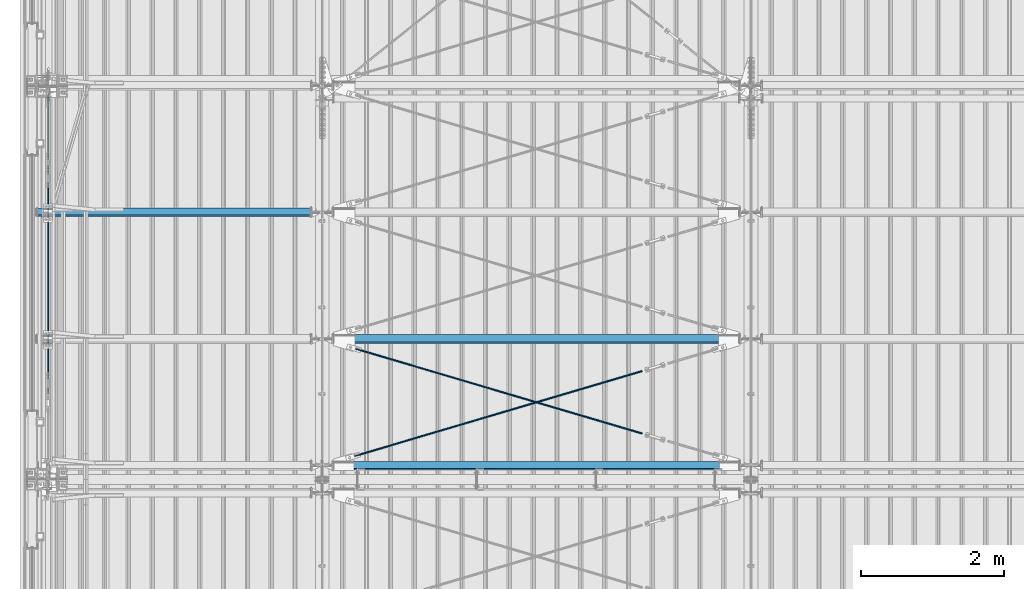
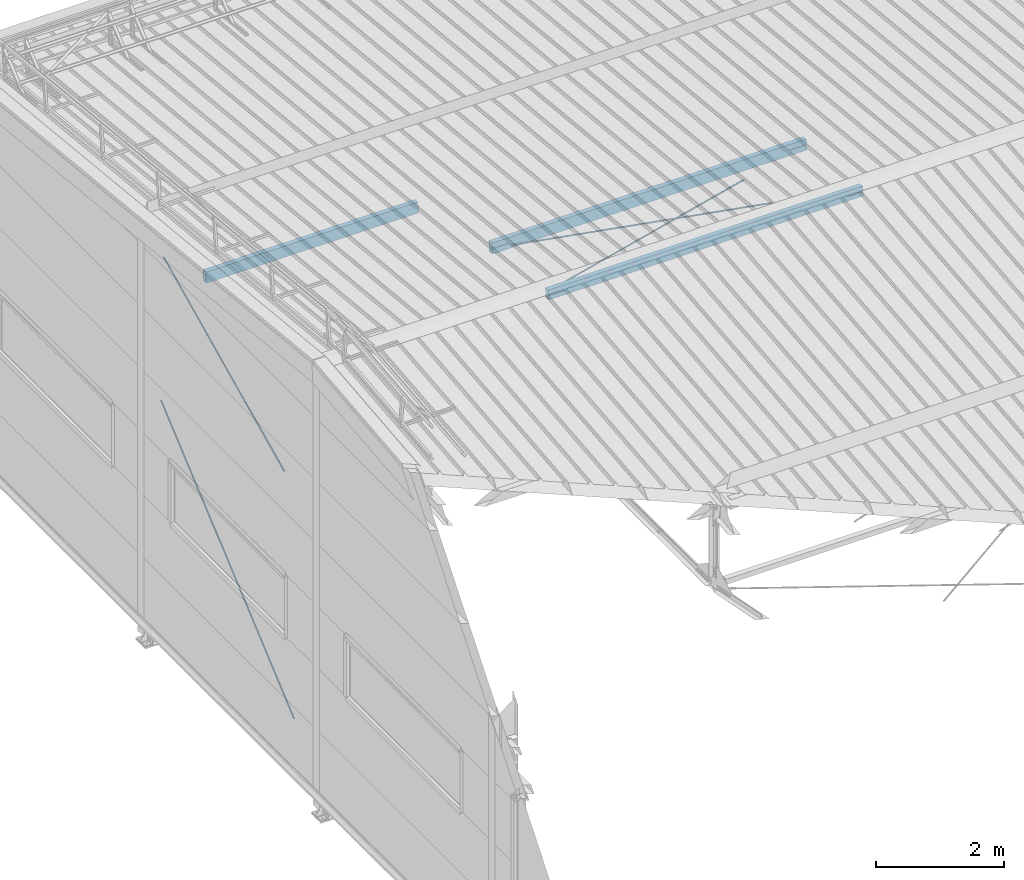
# One storey, part 248 of 709: 5 beams, 2 members, 8 openings, 7 elements without a shape of their own.
"""IFC4 building model written with IfcOpenShell, lengths in millimetres."""

from ifc_helpers import new_model, si_unit, direction, frame, origin_with_axes, place, context, subcontext, project, spatial, line, indexed_curve, outline, extrude, polygons, material, element, aggregate, save


model = new_model("IFC4")

# Units and contexts
model_context = context("Model", 3, precision=0.2, world=origin_with_axes(), true_north=direction((0.0, 1.0)))
body_context = subcontext(model_context, "Body", "Model", "MODEL_VIEW")
reference_context = subcontext(model_context, "Reference", "Model", "MODEL_VIEW")
ifc_project = project(units=[si_unit("LENGTHUNIT", "METRE", prefix="MILLI"), si_unit("AREAUNIT", "SQUARE_METRE"), si_unit("VOLUMEUNIT", "CUBIC_METRE"), si_unit("MASSUNIT", "GRAM", prefix="KILO"), si_unit("TIMEUNIT", "SECOND"), si_unit("PLANEANGLEUNIT", "RADIAN"), si_unit("SOLIDANGLEUNIT", "STERADIAN"), si_unit("THERMODYNAMICTEMPERATUREUNIT", "DEGREE_CELSIUS"), si_unit("LUMINOUSINTENSITYUNIT", "LUMEN")], contexts=[model_context])

# Site, building, storey
site_placement = place(None, origin_with_axes())
site = spatial("IfcSite", under=ifc_project, at=site_placement, CompositionType="ELEMENT")
building_placement = place(site_placement, origin_with_axes())
building = spatial("IfcBuilding", under=site, at=building_placement, Name="Undefined", CompositionType="ELEMENT")
storey_placement = place(building_placement, origin_with_axes())
storey = spatial("IfcBuildingStorey", under=building, at=storey_placement, Name="Undefined", CompositionType="ELEMENT", Elevation=0.0)

# Assembly, member, voiding feature
assembly_1_placement = place(storey_placement, frame((165.0, 16425.5, 4480.0), z_axis=(-1.0, 0.0, 0.0), x_axis=(0.0, -0.7603239329, -0.649544084)))
assembly_1 = element("IfcElementAssembly", 1, at=assembly_1_placement, inside=storey)
ifc_material_1 = material(Name="C355-5", Category="STEEL")
member_1_placement = place(assembly_1_placement, origin_with_axes())
member_1 = element("IfcMember", 2, at=member_1_placement, material=ifc_material_1, ObjectType="514", context=body_context, shape_type="Tessellation", body=[
    polygons([(5725.77433, 7.36121, 4.25), (5725.77433, 6.01041, 6.01041), (5725.77433, 4.25, 7.36122), (5725.77433, 2.19996, 8.21037), (5725.77433, 0.0, 8.5), (5725.77433, -2.19996, 8.21037), (5725.77433, -4.25, 7.36122), (5725.77433, -6.01041, 6.01041), (5725.77433, -7.36122, 4.25), (5725.77433, -8.21037, 2.19996), (5725.77433, -8.5, 0.0), (5725.77433, -8.21037, -2.19996), (5725.77433, -7.36122, -4.25), (5725.77433, -6.01041, -6.01041), (5725.77433, -4.25, -7.36122), (5725.77433, -2.19996, -8.21037), (5725.77433, 0.0, -8.5), (5725.77433, 2.19996, -8.21037), (5725.77433, 4.25, -7.36122), (5725.77433, 6.01041, -6.01041), (5725.77433, 7.36121, -4.25), (5725.77433, 8.21037, -2.19996), (5725.77433, 8.5, 0.0), (5725.77433, 8.21037, 2.19996), (5545.77433, 8.21037, 2.19996), (5545.77433, 7.36121, 4.25), (5545.77433, 6.01041, 6.01041), (5545.77433, 4.25, 7.36122), (5545.77433, 2.19996, 8.21037), (5545.77433, 0.0, 8.5), (5545.77433, -2.19996, 8.21037), (5545.77433, -4.25, 7.36122), (5545.77433, -6.01041, 6.01041), (5545.77433, -7.36122, 4.25), (5545.77433, -8.21037, 2.19996), (5545.77433, -8.5, 0.0), (5545.77433, -8.21037, -2.19996), (5545.77433, -7.36122, -4.25), (5545.77433, -6.01041, -6.01041), (5545.77433, -4.25, -7.36122), (5545.77433, -2.19996, -8.21037), (5545.77433, 0.0, -8.5), (5545.77433, 2.19996, -8.21037), (5545.77433, 4.25, -7.36122), (5545.77433, 6.01041, -6.01041), (5545.77433, 7.36121, -4.25), (5545.77433, 8.21037, -2.19996), (5545.77433, 8.5, 0.0), (5545.77433, 10.0, 0.0), (5545.77433, 9.65926, 2.58819), (5545.77433, 8.66025, 5.0), (5545.77433, 7.07107, 7.07107), (5545.77433, 5.0, 8.66025), (5545.77433, 2.58819, 9.65926), (5545.77433, 0.0, 10.0), (5545.77433, -2.58819, 9.65926), (5545.77433, -5.0, 8.66025), (5545.77433, -7.07107, 7.07107), (5545.77433, -8.66025, 5.0), (5545.77433, -9.65926, 2.58819), (5545.77433, -10.0, 0.0), (5545.77433, -9.65926, -2.58819), (5545.77433, -8.66025, -5.0), (5545.77433, -7.07107, -7.07107), (5545.77433, -5.0, -8.66025), (5545.77433, -2.58819, -9.65926), (5545.77433, 0.0, -10.0), (5545.77433, 2.58819, -9.65926), (5545.77433, 5.0, -8.66025), (5545.77433, 7.07107, -7.07107), (5545.77433, 8.66025, -5.0), (5545.77433, 9.65926, -2.58819), (70.0, 2.58819, 9.65926), (70.0, 5.0, 8.66025), (70.0, 7.07107, 7.07107), (70.0, 8.66025, 5.0), (70.0, 9.65926, 2.58819), (70.0, 10.0, 0.0), (70.0, 9.65926, -2.58819), (70.0, 8.66025, -5.0), (70.0, 7.07107, -7.07107), (70.0, 5.0, -8.66025), (70.0, 2.58819, -9.65926), (70.0, 0.0, -10.0), (70.0, -2.58819, -9.65926), (70.0, -5.0, -8.66025), (70.0, -7.07107, -7.07107), (70.0, -8.66025, -5.0), (70.0, -9.65926, -2.58819), (70.0, -10.0, 0.0), (70.0, -9.65926, 2.58819), (70.0, -8.66025, 5.0), (70.0, -7.07107, 7.07107), (70.0, -5.0, 8.66025), (70.0, -2.58819, 9.65926), (70.0, 0.0, 10.0)], [[[1, 2, 3, 4, 5, 6, 7, 8, 9, 10, 11, 12, 13, 14, 15, 16, 17, 18, 19, 20, 21, 22, 23, 24]], [[24, 25, 26, 1]], [[1, 26, 27, 2]], [[2, 27, 28, 3]], [[3, 28, 29, 4]], [[4, 29, 30, 5]], [[5, 30, 31, 6]], [[6, 31, 32, 7]], [[7, 32, 33, 8]], [[8, 33, 34, 9]], [[9, 34, 35, 10]], [[10, 35, 36, 11]], [[11, 36, 37, 12]], [[12, 37, 38, 13]], [[13, 38, 39, 14]], [[14, 39, 40, 15]], [[15, 40, 41, 16]], [[16, 41, 42, 17]], [[17, 42, 43, 18]], [[18, 43, 44, 19]], [[19, 44, 45, 20]], [[20, 45, 46, 21]], [[21, 46, 47, 22]], [[22, 47, 48, 23]], [[23, 48, 25, 24]], [[49, 50, 51, 52, 53, 54, 55, 56, 57, 58, 59, 60, 61, 62, 63, 64, 65, 66, 67, 68, 69, 70, 71, 72], [47, 46, 45, 44, 43, 42, 41, 40, 39, 38, 37, 36, 35, 34, 33, 32, 31, 30, 29, 28, 27, 26, 25, 48]], [[73, 74, 75, 76, 77, 78, 79, 80, 81, 82, 83, 84, 85, 86, 87, 88, 89, 90, 91, 92, 93, 94, 95, 96]], [[79, 78, 49, 72]], [[80, 79, 72, 71]], [[81, 80, 71, 70]], [[82, 81, 70, 69]], [[83, 82, 69, 68]], [[84, 83, 68, 67]], [[85, 84, 67, 66]], [[86, 85, 66, 65]], [[87, 86, 65, 64]], [[88, 87, 64, 63]], [[89, 88, 63, 62]], [[90, 89, 62, 61]], [[91, 90, 61, 60]], [[92, 91, 60, 59]], [[93, 92, 59, 58]], [[94, 93, 58, 57]], [[95, 94, 57, 56]], [[96, 95, 56, 55]], [[73, 96, 55, 54]], [[74, 73, 54, 53]], [[75, 74, 53, 52]], [[76, 75, 52, 51]], [[77, 76, 51, 50]], [[78, 77, 50, 49]]], closed=True),
])
voiding_feature_1_placement = place(member_1_placement, frame((5725.77433, 0.0, 0.0), z_axis=(0.0, 1.0, 0.0), x_axis=(-1.0, 0.0, 0.0)))
element("IfcVoidingFeature", 3, at=voiding_feature_1_placement, cuts=member_1, PredefinedType="HOLE", context=reference_context, identifier="Reference", shape_type="SolidModel", body=[
    extrude(outline(indexed_curve([(10.5, 0.0), (10.14222, 2.7176), (9.09327, 5.25), (7.42462, 7.42462), (5.25, 9.09327), (2.7176, 10.14222), (0.0, 10.5), (-2.7176, 10.14222), (-5.25, 9.09327), (-7.42462, 7.42462), (-9.09327, 5.25), (-10.14222, 2.7176), (-10.5, 0.0), (-10.14222, -2.7176), (-9.09327, -5.25), (-7.42462, -7.42462), (-5.25, -9.09327), (-2.7176, -10.14222), (0.0, -10.5), (2.7176, -10.14222), (5.25, -9.09327), (7.42462, -7.42462), (9.09327, -5.25), (10.14222, -2.7176)], segments=[line(1, 2, 3, 4, 5, 6, 7, 8, 9, 10, 11, 12, 13, 14, 15, 16, 17, 18, 19, 20, 21, 22, 23, 24, 1)])), frame((0.0, 0.0, 0.0), z_axis=(-1.0, 0.0, 0.0), x_axis=(0.0, 0.0, 1.0)), (0.0, 0.0, -1.0), 180.0),
])
aggregate(assembly_1, [member_1])

assembly_2_placement = place(storey_placement, frame((165.0, 16500.0, 7320.68854), z_axis=(-1.0, 0.0, 0.0), x_axis=(0.0, -0.9030466941, -0.429542394)))
assembly_2 = element("IfcElementAssembly", 4, at=assembly_2_placement, inside=storey)
member_2_placement = place(assembly_2_placement, origin_with_axes())
member_2 = element("IfcMember", 5, at=member_2_placement, material=ifc_material_1, ObjectType="517", context=body_context, shape_type="Tessellation", body=[
    polygons([(4597.99497, 7.36122, 4.25), (4597.99497, 6.01041, 6.01041), (4597.99497, 4.25, 7.36122), (4597.99497, 2.19996, 8.21037), (4597.99497, 0.0, 8.5), (4597.99497, -2.19996, 8.21037), (4597.99497, -4.25, 7.36122), (4597.99497, -6.01041, 6.01041), (4597.99497, -7.36121, 4.25), (4597.99497, -8.21037, 2.19996), (4597.99497, -8.5, 0.0), (4597.99497, -8.21037, -2.19996), (4597.99497, -7.36121, -4.25), (4597.99497, -6.01041, -6.01041), (4597.99497, -4.25, -7.36122), (4597.99497, -2.19996, -8.21037), (4597.99497, 0.0, -8.5), (4597.99497, 2.19996, -8.21037), (4597.99497, 4.25, -7.36122), (4597.99497, 6.01041, -6.01041), (4597.99497, 7.36122, -4.25), (4597.99497, 8.21037, -2.19996), (4597.99497, 8.5, 0.0), (4597.99497, 8.21037, 2.19996), (4417.99497, 8.21037, 2.19996), (4417.99497, 7.36122, 4.25), (4417.99497, 6.01041, 6.01041), (4417.99497, 4.25, 7.36122), (4417.99497, 2.19996, 8.21037), (4417.99497, 0.0, 8.5), (4417.99497, -2.19996, 8.21037), (4417.99497, -4.25, 7.36122), (4417.99497, -6.01041, 6.01041), (4417.99497, -7.36121, 4.25), (4417.99497, -8.21037, 2.19996), (4417.99497, -8.5, 0.0), (4417.99497, -8.21037, -2.19996), (4417.99497, -7.36121, -4.25), (4417.99497, -6.01041, -6.01041), (4417.99497, -4.25, -7.36122), (4417.99497, -2.19996, -8.21037), (4417.99497, 0.0, -8.5), (4417.99497, 2.19996, -8.21037), (4417.99497, 4.25, -7.36122), (4417.99497, 6.01041, -6.01041), (4417.99497, 7.36122, -4.25), (4417.99497, 8.21037, -2.19996), (4417.99497, 8.5, 0.0), (4417.99497, 10.0, 0.0), (4417.99497, 9.65926, 2.58819), (4417.99497, 8.66025, 5.0), (4417.99497, 7.07107, 7.07107), (4417.99497, 5.0, 8.66025), (4417.99497, 2.58819, 9.65926), (4417.99497, 0.0, 10.0), (4417.99497, -2.58819, 9.65926), (4417.99497, -5.0, 8.66025), (4417.99497, -7.07107, 7.07107), (4417.99497, -8.66025, 5.0), (4417.99497, -9.65926, 2.58819), (4417.99497, -10.0, 0.0), (4417.99497, -9.65926, -2.58819), (4417.99497, -8.66025, -5.0), (4417.99497, -7.07107, -7.07107), (4417.99497, -5.0, -8.66025), (4417.99497, -2.58819, -9.65926), (4417.99497, 0.0, -10.0), (4417.99497, 2.58819, -9.65926), (4417.99497, 5.0, -8.66025), (4417.99497, 7.07107, -7.07107), (4417.99497, 8.66025, -5.0), (4417.99497, 9.65926, -2.58819), (227.75045, 2.58819, 9.65926), (227.75045, 5.0, 8.66025), (227.75045, 7.07107, 7.07107), (227.75045, 8.66025, 5.0), (227.75045, 9.65926, 2.58819), (227.75045, 10.0, 0.0), (227.75045, 9.65926, -2.58819), (227.75045, 8.66025, -5.0), (227.75045, 7.07107, -7.07107), (227.75045, 5.0, -8.66025), (227.75045, 2.58819, -9.65926), (227.75045, 0.0, -10.0), (227.75045, -2.58819, -9.65926), (227.75045, -5.0, -8.66025), (227.75045, -7.07107, -7.07107), (227.75045, -8.66025, -5.0), (227.75045, -9.65926, -2.58819), (227.75045, -10.0, 0.0), (227.75045, -9.65926, 2.58819), (227.75045, -8.66025, 5.0), (227.75045, -7.07107, 7.07107), (227.75045, -5.0, 8.66025), (227.75045, -2.58819, 9.65926), (227.75045, 0.0, 10.0)], [[[1, 2, 3, 4, 5, 6, 7, 8, 9, 10, 11, 12, 13, 14, 15, 16, 17, 18, 19, 20, 21, 22, 23, 24]], [[24, 25, 26, 1]], [[1, 26, 27, 2]], [[2, 27, 28, 3]], [[3, 28, 29, 4]], [[4, 29, 30, 5]], [[5, 30, 31, 6]], [[6, 31, 32, 7]], [[7, 32, 33, 8]], [[8, 33, 34, 9]], [[9, 34, 35, 10]], [[10, 35, 36, 11]], [[11, 36, 37, 12]], [[12, 37, 38, 13]], [[13, 38, 39, 14]], [[14, 39, 40, 15]], [[15, 40, 41, 16]], [[16, 41, 42, 17]], [[17, 42, 43, 18]], [[18, 43, 44, 19]], [[19, 44, 45, 20]], [[20, 45, 46, 21]], [[21, 46, 47, 22]], [[22, 47, 48, 23]], [[23, 48, 25, 24]], [[49, 50, 51, 52, 53, 54, 55, 56, 57, 58, 59, 60, 61, 62, 63, 64, 65, 66, 67, 68, 69, 70, 71, 72], [47, 46, 45, 44, 43, 42, 41, 40, 39, 38, 37, 36, 35, 34, 33, 32, 31, 30, 29, 28, 27, 26, 25, 48]], [[73, 74, 75, 76, 77, 78, 79, 80, 81, 82, 83, 84, 85, 86, 87, 88, 89, 90, 91, 92, 93, 94, 95, 96]], [[79, 78, 49, 72]], [[80, 79, 72, 71]], [[81, 80, 71, 70]], [[82, 81, 70, 69]], [[83, 82, 69, 68]], [[84, 83, 68, 67]], [[85, 84, 67, 66]], [[86, 85, 66, 65]], [[87, 86, 65, 64]], [[88, 87, 64, 63]], [[89, 88, 63, 62]], [[90, 89, 62, 61]], [[91, 90, 61, 60]], [[92, 91, 60, 59]], [[93, 92, 59, 58]], [[94, 93, 58, 57]], [[95, 94, 57, 56]], [[96, 95, 56, 55]], [[73, 96, 55, 54]], [[74, 73, 54, 53]], [[75, 74, 53, 52]], [[76, 75, 52, 51]], [[77, 76, 51, 50]], [[78, 77, 50, 49]]], closed=True),
])
voiding_feature_2_placement = place(member_2_placement, frame((4597.99497, 0.0, 0.0), z_axis=(0.0, 1.0, 0.0), x_axis=(-1.0, 0.0, 0.0)))
element("IfcVoidingFeature", 6, at=voiding_feature_2_placement, cuts=member_2, PredefinedType="HOLE", context=reference_context, identifier="Reference", shape_type="SolidModel", body=[
    extrude(outline(indexed_curve([(10.5, 0.0), (10.14222, 2.7176), (9.09327, 5.25), (7.42462, 7.42462), (5.25, 9.09327), (2.7176, 10.14222), (0.0, 10.5), (-2.7176, 10.14222), (-5.25, 9.09327), (-7.42462, 7.42462), (-9.09327, 5.25), (-10.14222, 2.7176), (-10.5, 0.0), (-10.14222, -2.7176), (-9.09327, -5.25), (-7.42462, -7.42462), (-5.25, -9.09327), (-2.7176, -10.14222), (0.0, -10.5), (2.7176, -10.14222), (5.25, -9.09327), (7.42462, -7.42462), (9.09327, -5.25), (10.14222, -2.7176)], segments=[line(1, 2, 3, 4, 5, 6, 7, 8, 9, 10, 11, 12, 13, 14, 15, 16, 17, 18, 19, 20, 21, 22, 23, 24, 1)])), frame((0.0, 0.0, 0.0), z_axis=(-1.0, 0.0, 0.0), x_axis=(0.0, 0.0, 1.0)), (0.0, 0.0, -1.0), 180.0),
])
aggregate(assembly_2, [member_2])

# Assembly, beam, voiding feature
assembly_3_placement = place(storey_placement, frame((4000.0, 11190.84566, 8217.41945), z_axis=(0.2847296511, -0.9538504697, 0.095385047), x_axis=(0.9586078582, 0.2833165921, -0.028331659)))
assembly_3 = element("IfcElementAssembly", 7, at=assembly_3_placement, inside=storey)
beam_1_placement = place(assembly_3_placement, origin_with_axes())
beam_1 = element("IfcBeam", 8, at=beam_1_placement, material=ifc_material_1, ObjectType="573", context=body_context, shape_type="Tessellation", body=[
    polygons([(4849.07659, 7.36121, 4.25), (4849.07659, 6.01041, 6.01041), (4849.07659, 4.25, 7.36122), (4849.07659, 2.19996, 8.21037), (4849.07659, 0.0, 8.5), (4849.07659, -2.19996, 8.21037), (4849.07659, -4.25, 7.36122), (4849.07659, -6.01041, 6.01041), (4849.07659, -7.36122, 4.25), (4849.07659, -8.21037, 2.19996), (4849.07659, -8.5, 0.0), (4849.07659, -8.21037, -2.19996), (4849.07659, -7.36122, -4.25), (4849.07659, -6.01041, -6.01041), (4849.07659, -4.25, -7.36122), (4849.07659, -2.19996, -8.21037), (4849.07659, 0.0, -8.5), (4849.07659, 2.19996, -8.21037), (4849.07659, 4.25, -7.36122), (4849.07659, 6.01041, -6.01041), (4849.07659, 7.36121, -4.25), (4849.07659, 8.21037, -2.19996), (4849.07659, 8.5, 0.0), (4849.07659, 8.21037, 2.19996), (4669.07659, 8.21037, 2.19996), (4669.07659, 7.36121, 4.25), (4669.07659, 6.01041, 6.01041), (4669.07659, 4.25, 7.36122), (4669.07659, 2.19996, 8.21037), (4669.07659, 0.0, 8.5), (4669.07659, -2.19996, 8.21037), (4669.07659, -4.25, 7.36122), (4669.07659, -6.01041, 6.01041), (4669.07659, -7.36122, 4.25), (4669.07659, -8.21037, 2.19996), (4669.07659, -8.5, 0.0), (4669.07659, -8.21037, -2.19996), (4669.07659, -7.36122, -4.25), (4669.07659, -6.01041, -6.01041), (4669.07659, -4.25, -7.36122), (4669.07659, -2.19996, -8.21037), (4669.07659, 0.0, -8.5), (4669.07659, 2.19996, -8.21037), (4669.07659, 4.25, -7.36122), (4669.07659, 6.01041, -6.01041), (4669.07659, 7.36121, -4.25), (4669.07659, 8.21037, -2.19996), (4669.07659, 8.5, 0.0), (4669.07659, 10.0, 0.0), (4669.07659, 9.65926, 2.58819), (4669.07659, 8.66025, 5.0), (4669.07659, 7.07107, 7.07107), (4669.07659, 5.0, 8.66025), (4669.07659, 2.58819, 9.65926), (4669.07659, 0.0, 10.0), (4669.07659, -2.58819, 9.65926), (4669.07659, -5.0, 8.66025), (4669.07659, -7.07107, 7.07107), (4669.07659, -8.66025, 5.0), (4669.07659, -9.65926, 2.58819), (4669.07659, -10.0, 0.0), (4669.07659, -9.65926, -2.58819), (4669.07659, -8.66025, -5.0), (4669.07659, -7.07107, -7.07107), (4669.07659, -5.0, -8.66025), (4669.07659, -2.58819, -9.65926), (4669.07659, 0.0, -10.0), (4669.07659, 2.58819, -9.65926), (4669.07659, 5.0, -8.66025), (4669.07659, 7.07107, -7.07107), (4669.07659, 8.66025, -5.0), (4669.07659, 9.65926, -2.58819), (468.68279, 2.58819, 9.65926), (468.68279, 5.0, 8.66025), (468.68279, 7.07107, 7.07107), (468.68279, 8.66025, 5.0), (468.68279, 9.65926, 2.58819), (468.68279, 10.0, 0.0), (468.68279, 9.65926, -2.58819), (468.68279, 8.66025, -5.0), (468.68279, 7.07107, -7.07107), (468.68279, 5.0, -8.66025), (468.68279, 2.58819, -9.65926), (468.68279, 0.0, -10.0), (468.68279, -2.58819, -9.65926), (468.68279, -5.0, -8.66025), (468.68279, -7.07107, -7.07107), (468.68279, -8.66025, -5.0), (468.68279, -9.65926, -2.58819), (468.68279, -10.0, 0.0), (468.68279, -9.65926, 2.58819), (468.68279, -8.66025, 5.0), (468.68279, -7.07107, 7.07107), (468.68279, -5.0, 8.66025), (468.68279, -2.58819, 9.65926), (468.68279, 0.0, 10.0)], [[[1, 2, 3, 4, 5, 6, 7, 8, 9, 10, 11, 12, 13, 14, 15, 16, 17, 18, 19, 20, 21, 22, 23, 24]], [[24, 25, 26, 1]], [[1, 26, 27, 2]], [[2, 27, 28, 3]], [[3, 28, 29, 4]], [[4, 29, 30, 5]], [[5, 30, 31, 6]], [[6, 31, 32, 7]], [[7, 32, 33, 8]], [[8, 33, 34, 9]], [[9, 34, 35, 10]], [[10, 35, 36, 11]], [[11, 36, 37, 12]], [[12, 37, 38, 13]], [[13, 38, 39, 14]], [[14, 39, 40, 15]], [[15, 40, 41, 16]], [[16, 41, 42, 17]], [[17, 42, 43, 18]], [[18, 43, 44, 19]], [[19, 44, 45, 20]], [[20, 45, 46, 21]], [[21, 46, 47, 22]], [[22, 47, 48, 23]], [[23, 48, 25, 24]], [[49, 50, 51, 52, 53, 54, 55, 56, 57, 58, 59, 60, 61, 62, 63, 64, 65, 66, 67, 68, 69, 70, 71, 72], [47, 46, 45, 44, 43, 42, 41, 40, 39, 38, 37, 36, 35, 34, 33, 32, 31, 30, 29, 28, 27, 26, 25, 48]], [[73, 74, 75, 76, 77, 78, 79, 80, 81, 82, 83, 84, 85, 86, 87, 88, 89, 90, 91, 92, 93, 94, 95, 96]], [[79, 78, 49, 72]], [[80, 79, 72, 71]], [[81, 80, 71, 70]], [[82, 81, 70, 69]], [[83, 82, 69, 68]], [[84, 83, 68, 67]], [[85, 84, 67, 66]], [[86, 85, 66, 65]], [[87, 86, 65, 64]], [[88, 87, 64, 63]], [[89, 88, 63, 62]], [[90, 89, 62, 61]], [[91, 90, 61, 60]], [[92, 91, 60, 59]], [[93, 92, 59, 58]], [[94, 93, 58, 57]], [[95, 94, 57, 56]], [[96, 95, 56, 55]], [[73, 96, 55, 54]], [[74, 73, 54, 53]], [[75, 74, 53, 52]], [[76, 75, 52, 51]], [[77, 76, 51, 50]], [[78, 77, 50, 49]]], closed=True),
])
voiding_feature_3_placement = place(beam_1_placement, frame((4849.07659, 0.0, 0.0), z_axis=(0.0, 1.0, 0.0), x_axis=(-1.0, 0.0, 0.0)))
element("IfcVoidingFeature", 9, at=voiding_feature_3_placement, cuts=beam_1, PredefinedType="HOLE", context=reference_context, identifier="Reference", shape_type="SolidModel", body=[
    extrude(outline(indexed_curve([(10.5, 0.0), (10.14222, 2.7176), (9.09327, 5.25), (7.42462, 7.42462), (5.25, 9.09327), (2.7176, 10.14222), (0.0, 10.5), (-2.7176, 10.14222), (-5.25, 9.09327), (-7.42462, 7.42462), (-9.09327, 5.25), (-10.14222, 2.7176), (-10.5, 0.0), (-10.14222, -2.7176), (-9.09327, -5.25), (-7.42462, -7.42462), (-5.25, -9.09327), (-2.7176, -10.14222), (0.0, -10.5), (2.7176, -10.14222), (5.25, -9.09327), (7.42462, -7.42462), (9.09327, -5.25), (10.14222, -2.7176)], segments=[line(1, 2, 3, 4, 5, 6, 7, 8, 9, 10, 11, 12, 13, 14, 15, 16, 17, 18, 19, 20, 21, 22, 23, 24, 1)])), frame((0.0, 0.0, 0.0), z_axis=(-1.0, 0.0, 0.0), x_axis=(0.0, 0.0, 1.0)), (0.0, 0.0, -1.0), 180.0),
])
aggregate(assembly_3, [beam_1])

assembly_4_placement = place(storey_placement, frame((4000.0, 12964.14591, 8040.08943), z_axis=(-0.2847296511, -0.9538504697, 0.095385047), x_axis=(0.9586078582, -0.2833165921, 0.028331659)))
assembly_4 = element("IfcElementAssembly", 10, at=assembly_4_placement, inside=storey)
beam_2_placement = place(assembly_4_placement, origin_with_axes())
beam_2 = element("IfcBeam", 11, at=beam_2_placement, material=ifc_material_1, ObjectType="572", context=body_context, shape_type="Tessellation", body=[
    polygons([(4849.07659, 7.36122, 4.25), (4849.07659, 6.01041, 6.01041), (4849.07659, 4.25, 7.36122), (4849.07659, 2.19996, 8.21037), (4849.07659, 0.0, 8.5), (4849.07659, -2.19996, 8.21037), (4849.07659, -4.25, 7.36122), (4849.07659, -6.01041, 6.01041), (4849.07659, -7.36121, 4.25), (4849.07659, -8.21037, 2.19996), (4849.07659, -8.5, 0.0), (4849.07659, -8.21037, -2.19996), (4849.07659, -7.36121, -4.25), (4849.07659, -6.01041, -6.01041), (4849.07659, -4.25, -7.36122), (4849.07659, -2.19996, -8.21037), (4849.07659, 0.0, -8.5), (4849.07659, 2.19996, -8.21037), (4849.07659, 4.25, -7.36122), (4849.07659, 6.01041, -6.01041), (4849.07659, 7.36122, -4.25), (4849.07659, 8.21037, -2.19996), (4849.07659, 8.5, 0.0), (4849.07659, 8.21037, 2.19996), (4669.07659, 8.21037, 2.19996), (4669.07659, 7.36122, 4.25), (4669.07659, 6.01041, 6.01041), (4669.07659, 4.25, 7.36122), (4669.07659, 2.19996, 8.21037), (4669.07659, 0.0, 8.5), (4669.07659, -2.19996, 8.21037), (4669.07659, -4.25, 7.36122), (4669.07659, -6.01041, 6.01041), (4669.07659, -7.36121, 4.25), (4669.07659, -8.21037, 2.19996), (4669.07659, -8.5, 0.0), (4669.07659, -8.21037, -2.19996), (4669.07659, -7.36121, -4.25), (4669.07659, -6.01041, -6.01041), (4669.07659, -4.25, -7.36122), (4669.07659, -2.19996, -8.21037), (4669.07659, 0.0, -8.5), (4669.07659, 2.19996, -8.21037), (4669.07659, 4.25, -7.36122), (4669.07659, 6.01041, -6.01041), (4669.07659, 7.36122, -4.25), (4669.07659, 8.21037, -2.19996), (4669.07659, 8.5, 0.0), (4669.07659, 10.0, 0.0), (4669.07659, 9.65926, 2.58819), (4669.07659, 8.66025, 5.0), (4669.07659, 7.07107, 7.07107), (4669.07659, 5.0, 8.66025), (4669.07659, 2.58819, 9.65926), (4669.07659, 0.0, 10.0), (4669.07659, -2.58819, 9.65926), (4669.07659, -5.0, 8.66025), (4669.07659, -7.07107, 7.07107), (4669.07659, -8.66025, 5.0), (4669.07659, -9.65926, 2.58819), (4669.07659, -10.0, 0.0), (4669.07659, -9.65926, -2.58819), (4669.07659, -8.66025, -5.0), (4669.07659, -7.07107, -7.07107), (4669.07659, -5.0, -8.66025), (4669.07659, -2.58819, -9.65926), (4669.07659, 0.0, -10.0), (4669.07659, 2.58819, -9.65926), (4669.07659, 5.0, -8.66025), (4669.07659, 7.07107, -7.07107), (4669.07659, 8.66025, -5.0), (4669.07659, 9.65926, -2.58819), (483.68279, 2.58819, 9.65926), (483.68279, 5.0, 8.66025), (483.68279, 7.07107, 7.07107), (483.68279, 8.66025, 5.0), (483.68279, 9.65926, 2.58819), (483.68279, 10.0, 0.0), (483.68279, 9.65926, -2.58819), (483.68279, 8.66025, -5.0), (483.68279, 7.07107, -7.07107), (483.68279, 5.0, -8.66025), (483.68279, 2.58819, -9.65926), (483.68279, 0.0, -10.0), (483.68279, -2.58819, -9.65926), (483.68279, -5.0, -8.66025), (483.68279, -7.07107, -7.07107), (483.68279, -8.66025, -5.0), (483.68279, -9.65926, -2.58819), (483.68279, -10.0, 0.0), (483.68279, -9.65926, 2.58819), (483.68279, -8.66025, 5.0), (483.68279, -7.07107, 7.07107), (483.68279, -5.0, 8.66025), (483.68279, -2.58819, 9.65926), (483.68279, 0.0, 10.0)], [[[1, 2, 3, 4, 5, 6, 7, 8, 9, 10, 11, 12, 13, 14, 15, 16, 17, 18, 19, 20, 21, 22, 23, 24]], [[24, 25, 26, 1]], [[1, 26, 27, 2]], [[2, 27, 28, 3]], [[3, 28, 29, 4]], [[4, 29, 30, 5]], [[5, 30, 31, 6]], [[6, 31, 32, 7]], [[7, 32, 33, 8]], [[8, 33, 34, 9]], [[9, 34, 35, 10]], [[10, 35, 36, 11]], [[11, 36, 37, 12]], [[12, 37, 38, 13]], [[13, 38, 39, 14]], [[14, 39, 40, 15]], [[15, 40, 41, 16]], [[16, 41, 42, 17]], [[17, 42, 43, 18]], [[18, 43, 44, 19]], [[19, 44, 45, 20]], [[20, 45, 46, 21]], [[21, 46, 47, 22]], [[22, 47, 48, 23]], [[23, 48, 25, 24]], [[49, 50, 51, 52, 53, 54, 55, 56, 57, 58, 59, 60, 61, 62, 63, 64, 65, 66, 67, 68, 69, 70, 71, 72], [47, 46, 45, 44, 43, 42, 41, 40, 39, 38, 37, 36, 35, 34, 33, 32, 31, 30, 29, 28, 27, 26, 25, 48]], [[73, 74, 75, 76, 77, 78, 79, 80, 81, 82, 83, 84, 85, 86, 87, 88, 89, 90, 91, 92, 93, 94, 95, 96]], [[79, 78, 49, 72]], [[80, 79, 72, 71]], [[81, 80, 71, 70]], [[82, 81, 70, 69]], [[83, 82, 69, 68]], [[84, 83, 68, 67]], [[85, 84, 67, 66]], [[86, 85, 66, 65]], [[87, 86, 65, 64]], [[88, 87, 64, 63]], [[89, 88, 63, 62]], [[90, 89, 62, 61]], [[91, 90, 61, 60]], [[92, 91, 60, 59]], [[93, 92, 59, 58]], [[94, 93, 58, 57]], [[95, 94, 57, 56]], [[96, 95, 56, 55]], [[73, 96, 55, 54]], [[74, 73, 54, 53]], [[75, 74, 53, 52]], [[76, 75, 52, 51]], [[77, 76, 51, 50]], [[78, 77, 50, 49]]], closed=True),
])
voiding_feature_4_placement = place(beam_2_placement, frame((4849.07659, 0.0, 0.0), z_axis=(0.0, 1.0, 0.0), x_axis=(-1.0, 0.0, 0.0)))
element("IfcVoidingFeature", 12, at=voiding_feature_4_placement, cuts=beam_2, PredefinedType="HOLE", context=reference_context, identifier="Reference", shape_type="SolidModel", body=[
    extrude(outline(indexed_curve([(10.5, 0.0), (10.14222, 2.7176), (9.09327, 5.25), (7.42462, 7.42462), (5.25, 9.09327), (2.7176, 10.14222), (0.0, 10.5), (-2.7176, 10.14222), (-5.25, 9.09327), (-7.42462, 7.42462), (-9.09327, 5.25), (-10.14222, 2.7176), (-10.5, 0.0), (-10.14222, -2.7176), (-9.09327, -5.25), (-7.42462, -7.42462), (-5.25, -9.09327), (-2.7176, -10.14222), (0.0, -10.5), (2.7176, -10.14222), (5.25, -9.09327), (7.42462, -7.42462), (9.09327, -5.25), (10.14222, -2.7176)], segments=[line(1, 2, 3, 4, 5, 6, 7, 8, 9, 10, 11, 12, 13, 14, 15, 16, 17, 18, 19, 20, 21, 22, 23, 24, 1)])), frame((0.0, 0.0, 0.0), z_axis=(-1.0, 0.0, 0.0), x_axis=(0.0, 0.0, 1.0)), (0.0, 0.0, -1.0), 180.0),
])
aggregate(assembly_4, [beam_2])

# Assembly, beam
assembly_5_placement = place(storey_placement, frame((4000.0, 14736.65012, 7854.7592), z_axis=(0.0, -0.9950371902, 0.099503719), x_axis=(-1.0, 0.0, 0.0)))
assembly_5 = element("IfcElementAssembly", 13, at=assembly_5_placement, inside=storey)
ifc_material_2 = material(Name="C355", Category="STEEL")
beam_3_placement = place(assembly_5_placement, origin_with_axes())
beam_3 = element("IfcBeam", 14, at=beam_3_placement, material=ifc_material_2, ObjectType="563", context=body_context, shape_type="Tessellation", body=[
    polygons([(155.0, -100.0, 50.0), (155.0, -100.0, -50.0), (3992.0, -100.0, -50.0), (3992.0, -100.0, 50.0), (155.0, 100.0, 50.0), (3992.0, 100.0, 50.0), (155.0, 100.0, -50.0), (3992.0, 100.0, -50.0), (155.0, -96.0, 46.0), (155.0, 96.0, 46.0), (3992.0, 96.0, 46.0), (3992.0, -96.0, 46.0), (155.0, -96.0, -46.0), (3992.0, -96.0, -46.0), (155.0, 96.0, -46.0), (3992.0, 96.0, -46.0)], [[[1, 2, 3, 4]], [[5, 1, 4, 6]], [[7, 5, 6, 8]], [[2, 7, 8, 3]], [[1, 5, 7, 2], [15, 10, 9, 13]], [[9, 10, 11, 12]], [[13, 9, 12, 14]], [[15, 13, 14, 16]], [[10, 15, 16, 11]], [[3, 8, 6, 4], [14, 12, 11, 16]]], closed=True),
])
aggregate(assembly_5, [beam_3])

# Assembly, beam, voiding features
assembly_6_placement = place(storey_placement, frame((10000.0, 11191.04467, 8219.40952), z_axis=(0.0, -0.9950371902, 0.099503719), x_axis=(-1.0, 0.0, 0.0)))
assembly_6 = element("IfcElementAssembly", 15, at=assembly_6_placement, inside=storey)
beam_4_placement = place(assembly_6_placement, origin_with_axes())
beam_4 = element("IfcBeam", 16, at=beam_4_placement, material=ifc_material_2, ObjectType="567", context=body_context, shape_type="Tessellation", body=[
    polygons([(442.92369, 5.0, 50.0), (442.92369, 5.0, 46.0), (155.0, 5.0, 46.0), (155.0, 5.0, 50.0), (442.92369, 15.0, 50.0), (442.92369, 15.0, 46.0), (155.0, 15.0, 50.0), (155.0, 15.0, 46.0), (442.92369, 5.0, -46.0), (442.92369, 5.0, -50.0), (155.0, 5.0, -50.0), (155.0, 5.0, -46.0), (442.92369, 15.0, -46.0), (442.92369, 15.0, -50.0), (155.0, 15.0, -46.0), (155.0, 15.0, -50.0), (155.0, 86.0, 46.0), (155.0, 86.0, -46.0), (5845.0, 86.0, -46.0), (5845.0, 86.0, 46.0), (155.0, 90.0, -50.0), (5845.0, 90.0, -50.0), (5845.0, 15.0, -50.0), (5557.07631, 15.0, -50.0), (5557.07631, 5.0, -50.0), (5845.0, 5.0, -50.0), (5845.0, -90.0, -50.0), (155.0, -90.0, -50.0), (5845.0, 15.0, -46.0), (5557.07631, 15.0, -46.0), (5557.07631, 5.0, -46.0), (5845.0, 5.0, -46.0), (155.0, -86.0, -46.0), (155.0, -86.0, 46.0), (5845.0, -86.0, 46.0), (5845.0, -86.0, -46.0), (5557.07631, 5.0, 50.0), (5557.07631, 5.0, 46.0), (5557.07631, 15.0, 46.0), (5557.07631, 15.0, 50.0), (5845.0, 5.0, 50.0), (5845.0, 5.0, 46.0), (5845.0, -90.0, 50.0), (155.0, -90.0, 50.0), (5845.0, 15.0, 46.0), (5845.0, 15.0, 50.0), (5845.0, 90.0, 50.0), (155.0, 90.0, 50.0)], [[[1, 2, 3, 4]], [[5, 6, 2, 1]], [[7, 8, 6, 5]], [[9, 10, 11, 12]], [[13, 14, 10, 9]], [[15, 16, 14, 13]], [[17, 18, 19, 20]], [[21, 22, 23, 24, 25, 26, 27, 28, 11, 10, 14, 16]], [[29, 30, 24, 23]], [[31, 25, 24, 30]], [[32, 26, 25, 31]], [[33, 34, 35, 36]], [[37, 38, 39, 40]], [[41, 42, 38, 37]], [[43, 27, 26, 32, 36, 35, 42, 41]], [[44, 28, 27, 43]], [[34, 33, 12, 11, 28, 44, 4, 3]], [[17, 20, 45, 39, 38, 42, 35, 34, 3, 2, 6, 8]], [[46, 40, 39, 45]], [[20, 19, 29, 23, 22, 47, 46, 45]], [[21, 48, 47, 22]], [[4, 44, 43, 41, 37, 40, 46, 47, 48, 7, 5, 1]], [[48, 21, 16, 15, 18, 17, 8, 7]], [[12, 33, 36, 32, 31, 30, 29, 19, 18, 15, 13, 9]]], closed=True),
])
voiding_feature_5_placement = place(beam_4_placement, frame((5845.0, 10.0, 70.0), z_axis=(0.0, -1.0, 0.0), x_axis=(-1.0, 0.0, 0.0)))
element("IfcVoidingFeature", 17, at=voiding_feature_5_placement, cuts=beam_4, PredefinedType="HOLE", context=reference_context, identifier="Reference", shape_type="SolidModel", body=[
    extrude(outline(indexed_curve([(0.0, 0.0), (287.92369, 0.0), (287.92369, 154.61594), (262.29802, 240.89065), (0.0, 162.98181)], segments=[line(1, 2, 3, 4, 5, 1)])), frame((0.0, 0.0, 5.0), z_axis=(0.0, 0.0, 1.0), x_axis=(1.0, 0.0, 0.0)), (0.0, 0.0, -1.0), 10.0),
])
voiding_feature_6_placement = place(beam_4_placement, frame((442.92369, 10.0, 70.0), z_axis=(0.0, -1.0, 0.0), x_axis=(-1.0, 0.0, 0.0)))
element("IfcVoidingFeature", 18, at=voiding_feature_6_placement, cuts=beam_4, PredefinedType="HOLE", context=reference_context, identifier="Reference", shape_type="SolidModel", body=[
    extrude(outline(indexed_curve([(0.0, 0.0), (287.92369, 0.0), (287.92369, 162.98181), (25.62567, 240.89065), (0.0, 154.61594)], segments=[line(1, 2, 3, 4, 5, 1)])), frame((0.0, 0.0, 5.0), z_axis=(0.0, 0.0, 1.0), x_axis=(1.0, 0.0, 0.0)), (0.0, 0.0, -1.0), 10.0),
])
aggregate(assembly_6, [beam_4])

assembly_7_placement = place(storey_placement, frame((10000.0, 12963.34988, 8032.12913), z_axis=(0.0, -0.9950371902, 0.099503719), x_axis=(-1.0, 0.0, 0.0)))
assembly_7 = element("IfcElementAssembly", 19, at=assembly_7_placement, inside=storey)
beam_5_placement = place(assembly_7_placement, origin_with_axes())
beam_5 = element("IfcBeam", 20, at=beam_5_placement, material=ifc_material_2, ObjectType="566", context=body_context, shape_type="Tessellation", body=[
    polygons([(457.3028, -5.0, 50.0), (457.3028, -5.0, 46.0), (155.0, -5.0, 46.0), (155.0, -5.0, 50.0), (457.3028, 5.0, 50.0), (457.3028, 5.0, 46.0), (155.0, 5.0, 50.0), (155.0, 5.0, 46.0), (457.3028, -5.0, -46.0), (457.3028, -5.0, -50.0), (155.0, -5.0, -50.0), (155.0, -5.0, -46.0), (457.3028, 5.0, -46.0), (457.3028, 5.0, -50.0), (155.0, 5.0, -46.0), (155.0, 5.0, -50.0), (155.0, 96.0, 46.0), (155.0, 96.0, -46.0), (5845.0, 96.0, -46.0), (5845.0, 96.0, 46.0), (155.0, 100.0, -50.0), (5845.0, 100.0, -50.0), (5845.0, 5.0, -50.0), (5542.6972, 5.0, -50.0), (5542.6972, -5.0, -50.0), (5845.0, -5.0, -50.0), (5845.0, -100.0, -50.0), (155.0, -100.0, -50.0), (5845.00055, 5.0, -46.0), (5542.6972, 5.0, -46.0), (5542.6972, -5.0, -46.0), (5845.0, -5.0, -46.0), (155.0, -96.0, -46.0), (155.0, -96.0, 46.0), (5845.0, -96.0, 46.0), (5845.0, -96.0, -46.0), (5542.6972, -5.0, 50.0), (5542.6972, -5.0, 46.0), (5542.6972, 5.0, 46.0), (5542.6972, 5.0, 50.0), (5845.0, -5.0, 50.0), (5845.0, -5.0, 46.0), (5845.0, -100.0, 50.0), (155.0, -100.0, 50.0), (5845.0, 5.0, 46.0), (5845.00055, 5.0, 50.0), (5845.0, 100.0, 50.0), (155.0, 100.0, 50.0)], [[[1, 2, 3, 4]], [[5, 6, 2, 1]], [[7, 8, 6, 5]], [[9, 10, 11, 12]], [[13, 14, 10, 9]], [[15, 16, 14, 13]], [[17, 18, 19, 20]], [[21, 22, 23, 24, 25, 26, 27, 28, 11, 10, 14, 16]], [[29, 30, 24, 23]], [[31, 25, 24, 30]], [[32, 26, 25, 31]], [[33, 34, 35, 36]], [[37, 38, 39, 40]], [[41, 42, 38, 37]], [[43, 27, 26, 32, 36, 35, 42, 41]], [[44, 28, 27, 43]], [[34, 33, 12, 11, 28, 44, 4, 3]], [[17, 20, 45, 39, 38, 42, 35, 34, 3, 2, 6, 8]], [[46, 40, 39, 45]], [[20, 19, 29, 23, 22, 47, 46, 45]], [[21, 48, 47, 22]], [[4, 44, 43, 41, 37, 40, 46, 47, 48, 7, 5, 1]], [[48, 21, 16, 15, 18, 17, 8, 7]], [[12, 33, 36, 32, 31, 30, 29, 19, 18, 15, 13, 9]]], closed=True),
])
voiding_feature_7_placement = place(beam_5_placement, frame((5845.00055, 0.0, -92.98165), z_axis=(0.0, -1.0, 0.0), x_axis=(0.0, 0.0, 1.0)))
element("IfcVoidingFeature", 21, at=voiding_feature_7_placement, cuts=beam_5, Name="PLATE", PredefinedType="HOLE", context=reference_context, identifier="Reference", shape_type="SolidModel", body=[
    extrude(outline(indexed_curve([(0.0, 0.0), (185.9633, 0.0), (268.14324, 276.67769), (181.86854, 302.30336), (4.09476, 302.30336), (-82.17995, 276.67769)], segments=[line(1, 2, 3, 4, 5, 6, 1)])), frame((0.0, 0.0, 5.0), z_axis=(0.0, 0.0, 1.0), x_axis=(1.0, 0.0, 0.0)), (0.0, 0.0, -1.0), 10.0),
])
voiding_feature_8_placement = place(beam_5_placement, frame((154.99945, 0.0, 92.98165), z_axis=(0.0, -1.0, 0.0), x_axis=(0.0, 0.0, -1.0)))
element("IfcVoidingFeature", 22, at=voiding_feature_8_placement, cuts=beam_5, Name="PLATE", PredefinedType="HOLE", context=reference_context, identifier="Reference", shape_type="SolidModel", body=[
    extrude(outline(indexed_curve([(0.0, 0.0), (185.9633, 0.0), (268.14324, 276.67769), (181.86854, 302.30336), (4.09476, 302.30336), (-82.17995, 276.67769)], segments=[line(1, 2, 3, 4, 5, 6, 1)])), frame((0.0, 0.0, 5.0), z_axis=(0.0, 0.0, 1.0), x_axis=(1.0, 0.0, 0.0)), (0.0, 0.0, -1.0), 10.0),
])
aggregate(assembly_7, [beam_5])

save(model, "model.ifc")
